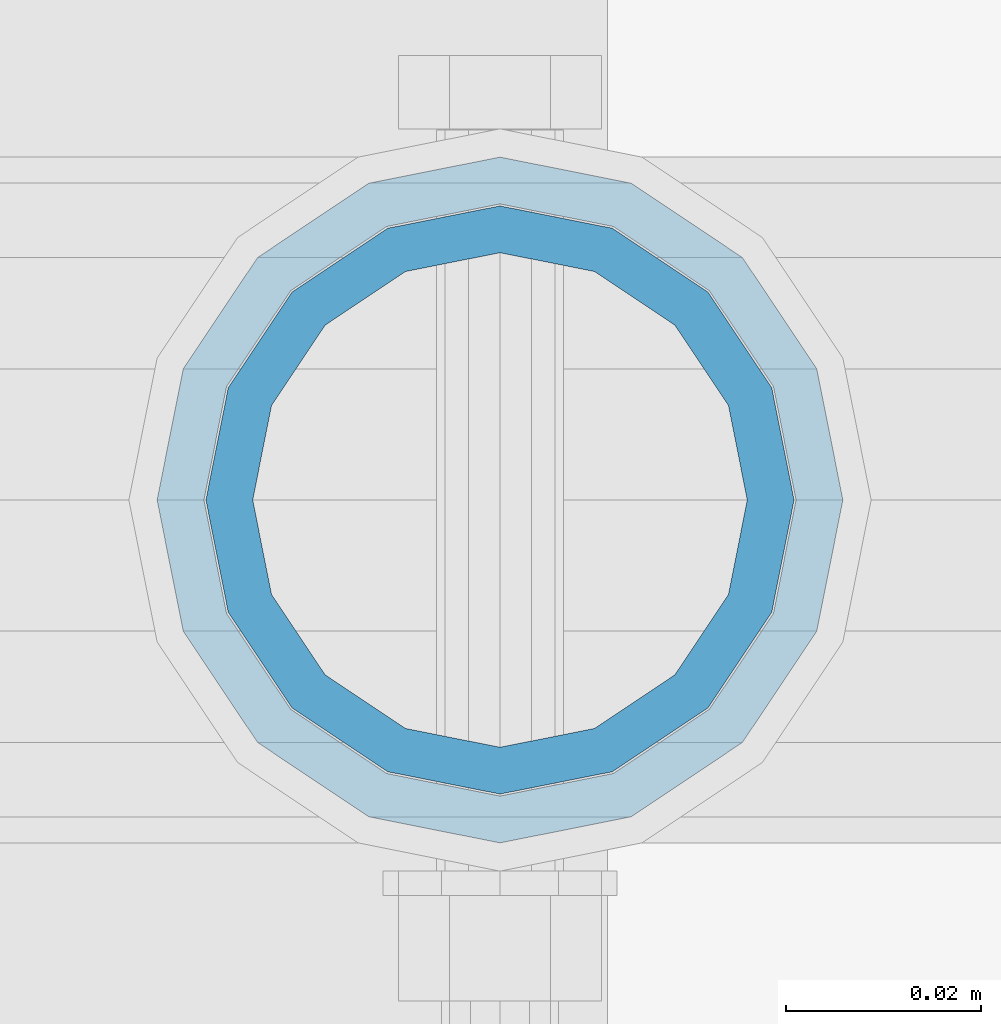
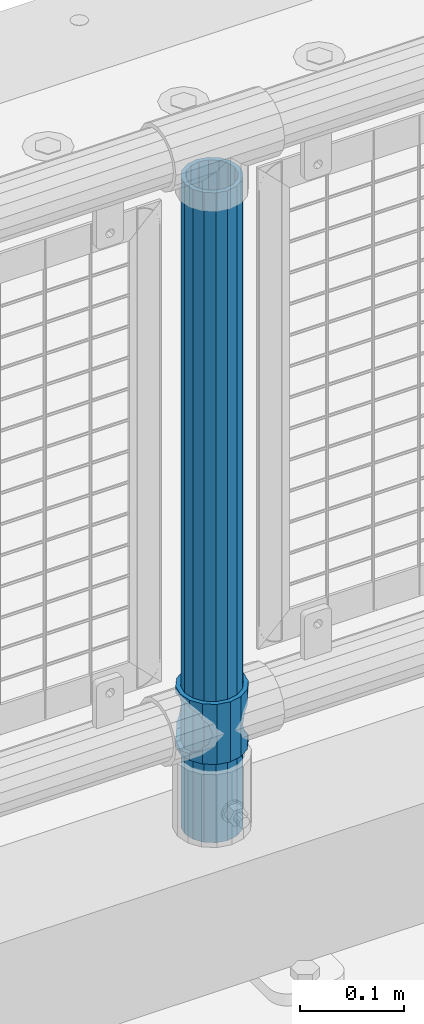
# One storey, part 96 of 242: 2 columns.
"""IFC2X3 building model written with IfcOpenShell, lengths in millimetres."""

import ifcopenshell
import ifcopenshell.guid

model = None  # the IFC model being written
_history = None  # IfcOwnerHistory: only IFC2X3 demands one
_inside = {}  # id of a spatial element -> (the spatial element, [elements in it])
_under = {}  # id of a project, library or spatial element -> (it, [spatial elements below it])
_declared = {}  # id of a project -> (the project, [libraries it declares])
_typed = {}  # id of a type object -> (the type object, [elements of that type])
_made_of = {}  # id of a material, layer set ... -> (it, [elements and type objects made of it])


def new_model(schema):
    """Start an empty IFC model of exactly this schema.

    Asked for "IFC4X3", IfcOpenShell would pick the latest addendum, in which some entities
    have other attributes; the version numbers below select the first issue.
    IFC2X3 requires an IfcOwnerHistory on every rooted entity: one is made here for all.
    """
    global model, _history
    if schema == "IFC4X3":
        model = ifcopenshell.file(schema_version=(4, 3, 0, 0))
    else:
        model = ifcopenshell.file(schema=schema)
    _inside.clear()
    _under.clear()
    _declared.clear()
    _typed.clear()
    _made_of.clear()
    _history = None
    if model.schema == "IFC2X3":
        org = make("IfcOrganization", Name="unknown")
        user = make(
            "IfcPersonAndOrganization",
            ThePerson=make("IfcPerson", FamilyName="unknown"),
            TheOrganization=org,
        )
        app = make(
            "IfcApplication",
            ApplicationDeveloper=org,
            Version="unknown",
            ApplicationFullName="unknown",
            ApplicationIdentifier="unknown",
        )
        _history = make(
            "IfcOwnerHistory",
            OwningUser=user,
            OwningApplication=app,
            ChangeAction="ADDED",
            CreationDate=0,
        )
    return model


def make(cls, **values):
    """One entity of the class cls with the attributes given. An attribute that is None is left unset."""
    return model.create_entity(
        cls, **{name: value for name, value in values.items() if value is not None}
    )


def rooted(cls, **values):
    """An entity with a GlobalId (a new one), such as an element, a storey or a relation."""
    return make(cls, GlobalId=ifcopenshell.guid.new(), OwnerHistory=_history, **values)


def si_unit(unit_type, name, prefix=None):
    """IfcSIUnit, for example si_unit("LENGTHUNIT", "METRE", prefix="MILLI")."""
    return make("IfcSIUnit", UnitType=unit_type, Prefix=prefix, Name=name)


def assignment(units):
    """IfcUnitAssignment: the units of a project."""
    return None if units is None else make("IfcUnitAssignment", Units=units)


def point(xyz):
    """IfcCartesianPoint."""
    return None if xyz is None else make("IfcCartesianPoint", Coordinates=xyz)


def direction(xyz):
    """IfcDirection."""
    return None if xyz is None else make("IfcDirection", DirectionRatios=xyz)


def frame(location, z_axis=None, x_axis=None):
    """IfcAxis2Placement3D, a coordinate frame: its origin and axes. An axis left out is left unset."""
    return make(
        "IfcAxis2Placement3D",
        Location=point(location),
        Axis=direction(z_axis),
        RefDirection=direction(x_axis),
    )


def origin_with_axes():
    """The frame at (0, 0, 0) with the z axis (0, 0, 1) and the x axis (1, 0, 0) written out."""
    return frame((0.0, 0.0, 0.0), z_axis=(0.0, 0.0, 1.0), x_axis=(1.0, 0.0, 0.0))


def place(relative_to, where):
    """IfcLocalPlacement: puts the frame where relative to a parent placement (None: the world)."""
    return make(
        "IfcLocalPlacement", PlacementRelTo=relative_to, RelativePlacement=where
    )


def context(
    kind, dimensions, precision=None, world=None, true_north=None, identifier=None
):
    """IfcGeometricRepresentationContext, for example the 3D "Model" context."""
    return make(
        "IfcGeometricRepresentationContext",
        ContextIdentifier=identifier,
        ContextType=kind,
        CoordinateSpaceDimension=dimensions,
        Precision=precision,
        WorldCoordinateSystem=world,
        TrueNorth=true_north,
    )


def subcontext(parent, identifier, kind, view, scale=None):
    """IfcGeometricRepresentationSubContext, for example "Body" below "Model"."""
    return make(
        "IfcGeometricRepresentationSubContext",
        ContextIdentifier=identifier,
        ContextType=kind,
        ParentContext=parent,
        TargetScale=scale,
        TargetView=view,
    )


def project(units=None, contexts=None):
    """IfcProject with its units and contexts."""
    return rooted(
        "IfcProject",
        Name="project",
        RepresentationContexts=contexts,
        UnitsInContext=assignment(units),
    )


def spatial(cls, under=None, at=None, **own):
    """A site, building, storey or space (cls), placed at a placement, below another one or the project."""
    s = rooted(cls, ObjectPlacement=at, **own)
    if under is not None:
        _under.setdefault(under.id(), (under, []))[1].append(s)
    return s


def faces_of(points, faces, orient=None, outer=None):
    """IfcFace entities. A face is a list of loops; a loop is a list of indices into points, from 0.

    orient and outer hold one flag for each loop. By default every Orientation is true, the
    first loop of a face is its IfcFaceOuterBound and the others are IfcFaceBound.
    """
    made = []
    for i, loops in enumerate(faces):
        bounds = []
        for j, loop in enumerate(loops):
            is_outer = j == 0 if outer is None else outer[i][j]
            bounds.append(
                make(
                    "IfcFaceOuterBound" if is_outer else "IfcFaceBound",
                    Bound=make("IfcPolyLoop", Polygon=[points[k] for k in loop]),
                    Orientation=True if orient is None else orient[i][j],
                )
            )
        made.append(make("IfcFace", Bounds=bounds))
    return made


def faceted_brep(points, faces, orient=None, outer=None, voids=None):
    """IfcFacetedBrep: a solid bounded by flat faces; with voids (closed shells), ...WithVoids."""
    shared = [point(p) for p in points]
    hull = make("IfcClosedShell", CfsFaces=faces_of(shared, faces, orient, outer))
    if voids is None:
        return make("IfcFacetedBrep", Outer=hull)
    return make(
        "IfcFacetedBrepWithVoids",
        Outer=hull,
        Voids=[
            make(cls, CfsFaces=faces_of(shared, fs, o, b)) for cls, fs, o, b in voids
        ],
    )


def shape(context_of_items, identifier, shape_type, items):
    """IfcShapeRepresentation: the items that make up one representation, for example the "Body"."""
    return make(
        "IfcShapeRepresentation",
        ContextOfItems=context_of_items,
        RepresentationIdentifier=identifier,
        RepresentationType=shape_type,
        Items=items,
    )


def material(Name=None, Category=None):
    """IfcMaterial."""
    return make("IfcMaterial", Name=Name, Category=Category)


def made_of(thing, what):
    """Note that an element or type object is made of a material, layer set ...; save() writes the relation."""
    if what is not None:
        _made_of.setdefault(what.id(), (what, []))[1].append(thing)
    return thing


def type_object(cls, material=None, **own):
    """A type object (cls), such as IfcWallType, which elements share."""
    return made_of(rooted(cls, **own), material)


def element(
    cls,
    number,
    at=None,
    inside=None,
    cuts=None,
    type_object=None,
    material=None,
    context=None,
    identifier="Body",
    shape_type=None,
    held_by="IfcProductDefinitionShape",
    body=None,
    shapes=None,
    **own,
):
    """One element of the class cls, such as IfcWall. Its Tag is "e" and its number.

    at: its placement. inside: the storey or other place that contains it. cuts: it is an
    opening in that element (IfcRelVoidsElement). A single representation is given by context,
    identifier, shape_type and body (its items); several are given by shapes. held_by: the class
    of the entity that holds the representations. save() writes the other relations.
    """
    e = rooted(cls, Tag="e%d" % number, ObjectPlacement=at, **own)
    if body is not None:
        shapes = [shape(context, identifier, shape_type, body)]
    if shapes is not None:
        e.Representation = make(held_by, Representations=shapes)
    if inside is not None:
        _inside.setdefault(inside.id(), (inside, []))[1].append(e)
    if cuts is not None:
        rooted(
            "IfcRelVoidsElement", RelatingBuildingElement=cuts, RelatedOpeningElement=e
        )
    if type_object is not None:
        _typed.setdefault(type_object.id(), (type_object, []))[1].append(e)
    return made_of(e, material)


def aggregate(whole, parts):
    """IfcRelAggregates: a whole, such as a stair, and the parts it consists of."""
    return rooted("IfcRelAggregates", RelatingObject=whole, RelatedObjects=parts)


def save(model, path):
    """Write the relations noted so far, then the file.

    IfcRelAggregates (storeys below a building ...), IfcRelContainedInSpatialStructure (elements
    in a storey), IfcRelDefinesByType, IfcRelAssociatesMaterial and IfcRelDeclares: one each for
    every whole, place, type object, material and project.
    """
    for whole, parts in _under.values():
        aggregate(whole, parts)
    for where, things in _inside.values():
        rooted(
            "IfcRelContainedInSpatialStructure",
            RelatedElements=things,
            RelatingStructure=where,
        )
    for kind, things in _typed.values():
        rooted("IfcRelDefinesByType", RelatedObjects=things, RelatingType=kind)
    for what, things in _made_of.values():
        rooted("IfcRelAssociatesMaterial", RelatedObjects=things, RelatingMaterial=what)
    for by, libraries in _declared.values():
        rooted("IfcRelDeclares", RelatingContext=by, RelatedDefinitions=libraries)
    model.write(path)


model = new_model("IFC2X3")

# Units and contexts
model_context = context("Model", 3, precision=1e-05, world=origin_with_axes())
body_context = subcontext(model_context, "Body", "Model", "MODEL_VIEW")
ifc_project = project(units=[si_unit("LENGTHUNIT", "METRE", prefix="MILLI"), si_unit("AREAUNIT", "SQUARE_METRE"), si_unit("VOLUMEUNIT", "CUBIC_METRE"), si_unit("MASSUNIT", "GRAM", prefix="KILO"), si_unit("TIMEUNIT", "SECOND"), si_unit("PLANEANGLEUNIT", "RADIAN"), si_unit("SOLIDANGLEUNIT", "STERADIAN"), si_unit("THERMODYNAMICTEMPERATUREUNIT", "DEGREE_CELSIUS"), si_unit("LUMINOUSINTENSITYUNIT", "LUMEN")], contexts=[model_context])

# Site, building, storey
site_placement = place(None, origin_with_axes())
site = spatial("IfcSite", under=ifc_project, at=site_placement, CompositionType="ELEMENT")
building_placement = place(site_placement, origin_with_axes())
building = spatial("IfcBuilding", under=site, at=building_placement, Name="Standard", CompositionType="ELEMENT")
storey_placement = place(building_placement, origin_with_axes())
storey = spatial("IfcBuildingStorey", under=building, at=storey_placement, Name="Undefined", CompositionType="ELEMENT", Elevation=0.0)

# Columns
ifc_material_1 = material()
column_type_1 = type_object("IfcColumnType", PredefinedType="NOTDEFINED")
column_1_placement = place(storey_placement, frame((-27132.0, -19335.5, 168.02), z_axis=(-1.0, 0.0, 0.0), x_axis=(0.0, 0.0, 1.0)))
element("IfcColumn", 1, at=column_1_placement, inside=storey, type_object=column_type_1, material=ifc_material_1, context=body_context, shape_type="Brep", body=[
    faceted_brep([(0.0, -25.3499999999985, 0.0), (0.0, -23.4203461491597, 9.70102501045403), (760.0, -23.4203461491597, 9.70102501045403), (760.0, -25.3499999999985, 0.0), (0.0, -17.9251569030785, 17.9251569030785), (760.0, -17.9251569030785, 17.9251569030785), (0.0, -9.70102501045403, 23.4203461491597), (760.0, -9.70102501045403, 23.4203461491597), (0.0, 0.0, 25.3499999999985), (760.0, 0.0, 25.3499999999985), (0.0, 9.70102501045403, 23.4203461491597), (760.0, 9.70102501045403, 23.4203461491597), (0.0, 17.9251569030785, 17.9251569030785), (760.0, 17.9251569030785, 17.9251569030785), (0.0, 23.4203461491597, 9.70102501045403), (760.0, 23.4203461491597, 9.70102501045403), (0.0, 25.3499999999985, 0.0), (760.0, 25.3499999999985, 0.0), (0.0, 23.4203461491597, -9.70102501045403), (760.0, 23.4203461491597, -9.70102501045403), (0.0, 17.9251569030785, -17.9251569030785), (760.0, 17.9251569030785, -17.9251569030785), (0.0, 9.70102501045403, -23.4203461491597), (760.0, 9.70102501045403, -23.4203461491597), (0.0, 0.0, -25.3499999999985), (760.0, 0.0, -25.3499999999985), (0.0, -9.70102501045403, -23.4203461491597), (760.0, -9.70102501045403, -23.4203461491597), (0.0, -17.9251569030785, -17.9251569030785), (760.0, -17.9251569030785, -17.9251569030785), (0.0, -23.4203461491597, -9.70102501045403), (760.0, -23.4203461491597, -9.70102501045403), (0.0, -30.1500000000015, 0.0), (0.0, -27.8549679052157, -11.5379054858058), (760.0, -27.8549679052157, -11.5379054858058), (760.0, -30.1500000000015, 0.0), (0.0, -21.3192694527752, -21.3192694527752), (760.0, -21.3192694527752, -21.3192694527752), (0.0, -11.5379054858058, -27.8549679052157), (760.0, -11.5379054858058, -27.8549679052157), (0.0, 0.0, -30.1500000000015), (760.0, 0.0, -30.1500000000015), (0.0, 11.5379054858058, -27.8549679052157), (760.0, 11.5379054858058, -27.8549679052157), (0.0, 21.3192694527752, -21.3192694527752), (760.0, 21.3192694527752, -21.3192694527752), (0.0, 27.8549679052157, -11.5379054858058), (760.0, 27.8549679052157, -11.5379054858058), (0.0, 30.1500000000015, 0.0), (760.0, 30.1500000000015, 0.0), (0.0, 27.8549679052157, 11.5379054858058), (760.0, 27.8549679052157, 11.5379054858058), (0.0, 21.3192694527752, 21.3192694527752), (760.0, 21.3192694527752, 21.3192694527752), (0.0, 11.5379054858058, 27.8549679052157), (760.0, 11.5379054858058, 27.8549679052157), (0.0, 0.0, 30.1500000000015), (760.0, 0.0, 30.1500000000015), (0.0, -11.5379054858058, 27.8549679052157), (760.0, -11.5379054858058, 27.8549679052157), (0.0, -21.3192694527752, 21.3192694527752), (760.0, -21.3192694527752, 21.3192694527752), (0.0, -27.8549679052157, 11.5379054858058), (760.0, -27.8549679052157, 11.5379054858058)], [[[0, 1, 2, 3]], [[1, 4, 5, 2]], [[4, 6, 7, 5]], [[6, 8, 9, 7]], [[8, 10, 11, 9]], [[10, 12, 13, 11]], [[12, 14, 15, 13]], [[14, 16, 17, 15]], [[16, 18, 19, 17]], [[18, 20, 21, 19]], [[20, 22, 23, 21]], [[22, 24, 25, 23]], [[24, 26, 27, 25]], [[26, 28, 29, 27]], [[28, 30, 31, 29]], [[30, 0, 3, 31]], [[32, 33, 34, 35]], [[33, 36, 37, 34]], [[36, 38, 39, 37]], [[38, 40, 41, 39]], [[40, 42, 43, 41]], [[42, 44, 45, 43]], [[44, 46, 47, 45]], [[46, 48, 49, 47]], [[48, 50, 51, 49]], [[50, 52, 53, 51]], [[52, 54, 55, 53]], [[54, 56, 57, 55]], [[56, 58, 59, 57]], [[58, 60, 61, 59]], [[60, 62, 63, 61]], [[62, 32, 35, 63]], [[37, 39, 41, 43, 45, 47, 49, 51, 53, 55, 57, 59, 61, 63, 35, 34], [5, 7, 9, 11, 13, 15, 17, 19, 21, 23, 25, 27, 29, 31, 3, 2]], [[62, 60, 58, 56, 54, 52, 50, 48, 46, 44, 42, 40, 38, 36, 33, 32], [30, 28, 26, 24, 22, 20, 18, 16, 14, 12, 10, 8, 6, 4, 1, 0]]]),
])
ifc_material_2 = material(Name="Misc_Undefined")
column_type_2 = type_object("IfcColumnType", PredefinedType="NOTDEFINED")
column_2_placement = place(storey_placement, frame((-27132.0, -19335.5, 263.02), z_axis=(-1.0, 0.0, 0.0), x_axis=(0.0, 0.0, 1.0)))
element("IfcColumn", 2, at=column_2_placement, inside=storey, type_object=column_type_2, material=ifc_material_2, context=body_context, shape_type="Brep", body=[
    faceted_brep([(63.1897438117172, 11.614442172282, -32.8397438117245), (63.1897438117172, 11.614442172282, -28.0397438117143), (56.6106908090114, 21.46069080901, -21.4606908090136), (56.6106908090114, 21.46069080901, -27.1226768591077), (61.9623795176744, 13.4513226476338, -32.4743655677739), (46.7644421722801, 28.0397438117179, -11.6144421722784), (46.7644421722801, 28.0397438117179, -20.0882031229849), (51.5310424080006, 24.8548033587067, -24.8548033587067), (35.1500000000015, 30.35, 0.0), (35.1499999999996, 30.3499999999985, -16.6306603983685), (23.5355578277192, 28.0397438117179, -11.6144421722784), (23.5355578277192, 28.0397438117179, -20.0882031229849), (18.7689575919987, 24.8548033587067, -24.8548033587067), (13.6893091909879, 21.46069080901, -21.4606908090136), (13.6893091909879, 21.46069080901, -27.1226768591077), (8.33762048232262, 13.4513226476338, -32.4743655677739), (7.11025618828211, 11.614442172282, -28.0397438117143), (7.11025618828211, 11.614442172282, -32.8397438117245), (4.79999999999961, 0.0, -30.3499999999985), (4.79999999999961, 0.0, -35.1500000000015), (7.11025618828211, -11.614442172282, -28.0397438117143), (7.11025618828211, -11.614442172282, -32.8397438117172), (13.6893091909879, -21.46069080901, -21.4606908090136), (13.6893091909879, -21.46069080901, -27.1226768591077), (8.33762048232484, -13.4513226476338, -32.4743655677739), (23.5355578277191, -28.0397438117179, -11.6144421722784), (23.5355578277191, -28.0397438117179, -20.0882031229921), (18.7689575919975, -24.8548033587067, -24.8548033587067), (35.1500000000015, -30.35, 0.0), (35.1499999999996, -30.3499999999985, -16.6306603983758), (46.7644421722801, -28.0397438117179, -11.6144421722784), (46.7644421722801, -28.0397438117179, -20.0882031229921), (51.5310424079973, -24.8548033587067, -24.8548033587067), (56.6106908090114, -21.46069080901, -21.4606908090136), (56.6106908090114, -21.46069080901, -27.1226768591077), (61.9623795176767, -13.4513226476338, -32.4743655677739), (63.1897438117172, -11.614442172282, -28.0397438117143), (63.1897438117172, -11.614442172282, -32.8397438117172), (65.4999999999997, 0.0, -30.3499999999985), (65.4999999999997, 0.0, -35.1500000000015), (0.0, -28.0397438117179, -11.6144421722784), (0.0, -30.3499999999985, 0.0), (0.0, -21.46069080901, -21.4606908090136), (0.0, -11.614442172282, -28.0397438117143), (0.0, 0.0, -30.3499999999985), (0.0, 11.614442172282, -28.0397438117143), (0.0, 21.46069080901, -21.4606908090136), (0.0, 28.0397438117179, -11.6144421722784), (0.0, 30.3499999999985, 0.0), (0.0, 28.0397438117179, 11.6144421722784), (23.5355578277192, 28.0397438117179, 11.614442172282), (0.0, 21.46069080901, 21.4606908090136), (13.6893091909879, 21.46069080901, 21.46069080901), (0.0, 11.614442172282, 28.0397438117143), (7.11025618828211, 11.614442172282, 28.0397438117179), (0.0, 0.0, 30.3499999999985), (4.79999999999961, 0.0, 30.3499999999985), (0.0, -11.614442172282, 28.0397438117143), (7.11025618828205, -11.614442172282, 28.0397438117179), (0.0, -21.46069080901, 21.4606908090136), (13.6893091909879, -21.46069080901, 21.46069080901), (0.0, -28.0397438117179, 11.6144421722784), (23.5355578277191, -28.0397438117179, 11.614442172282), (0.0, -32.4743655677703, 13.4513226476338), (0.0, -35.1500000000015, 0.0), (70.2999999999993, -35.1500000000015, 0.0), (70.2999999999993, -32.4743655677703, 13.4513226476338), (0.0, 13.4513226476338, -32.4743655677739), (0.0, 24.8548033587067, -24.8548033587067), (0.0, 0.0, -35.1500000000015), (0.0, -13.4513226476338, -32.4743655677739), (0.0, -24.8548033587067, -24.8548033587067), (0.0, -24.8548033587067, 24.8548033587067), (0.0, -13.4513226476338, 32.4743655677739), (0.0, 0.0, 35.1500000000015), (0.0, 13.4513226476338, 32.4743655677739), (0.0, 24.8548033587067, 24.8548033587067), (0.0, 32.4743655677703, 13.4513226476338), (0.0, 35.1500000000015, 0.0), (0.0, 32.4743655677703, -13.4513226476338), (0.0, -32.4743655677703, -13.4513226476338), (70.2999999999993, 32.4743655677703, 13.4513226476338), (70.2999999999993, 35.1500000000015, 0.0), (70.2999999999993, 32.4743655677703, -13.4513226476338), (70.2999999999993, 24.8548033587067, -24.8548033587067), (70.2999999999993, 13.4513226476338, -32.4743655677739), (70.2999999999993, 0.0, -35.1500000000015), (70.2999999999993, -13.4513226476338, -32.4743655677739), (70.2999999999993, -24.8548033587067, -24.8548033587067), (70.2999999999993, -32.4743655677703, -13.4513226476338), (70.2999999999993, 28.0397438117179, 11.6144421722784), (70.2999999999993, 21.46069080901, 21.4606908090136), (56.6106908090114, 21.46069080901, 21.46069080901), (46.7644421722801, 28.0397438117179, 11.614442172282), (70.2999999999993, 11.614442172282, 28.0397438117143), (63.1897438117172, 11.614442172282, 28.0397438117179), (70.2999999999993, 0.0, 30.3499999999985), (65.4999999999997, 0.0, 30.3499999999985), (70.2999999999993, -11.614442172282, 28.0397438117143), (63.1897438117172, -11.614442172282, 28.0397438117179), (70.2999999999993, -21.46069080901, 21.4606908090136), (56.6106908090114, -21.46069080901, 21.46069080901), (70.2999999999993, -28.0397438117179, 11.6144421722784), (46.7644421722801, -28.0397438117179, 11.614442172282), (70.2999999999993, -11.614442172282, -28.0397438117143), (70.2999999999993, 0.0, -30.3499999999985), (70.2999999999993, -21.46069080901, -21.4606908090136), (70.2999999999993, -28.0397438117179, -11.6144421722784), (70.2999999999993, -30.3499999999985, 0.0), (70.2999999999993, 24.8548033587067, 24.8548033587067), (70.2999999999993, 13.4513226476338, 32.4743655677739), (70.2999999999993, 0.0, 35.1500000000015), (70.2999999999993, -13.4513226476338, 32.4743655677739), (70.2999999999993, -24.8548033587067, 24.8548033587067), (70.2999999999993, 30.3499999999985, 0.0), (70.2999999999993, 28.0397438117179, -11.6144421722784), (70.2999999999993, 21.46069080901, -21.4606908090136), (70.2999999999993, 11.614442172282, -28.0397438117143), (61.9623795176744, 13.4513226476338, 32.4743655677703), (51.5310424080006, 24.8548033587067, 24.8548033587067), (56.6106908090114, 21.46069080901, 27.1226768591077), (65.4999999999997, 0.0, 35.1500000000015), (63.1897438117172, 11.614442172282, 32.8397438117136), (63.1897438117172, -11.614442172282, 32.8397438117172), (61.9623795176767, -13.4513226476338, 32.4743655677703), (56.6106908090114, -21.46069080901, 27.1226768591077), (51.5310424080038, -24.8548033587067, 24.8548033587067), (18.7689575919954, -24.8548033587067, 24.8548033587067), (46.7644421722801, -28.0397438117179, 20.0882031229885), (35.1499999999996, -30.3499999999985, 16.6306603983685), (23.5355578277191, -28.0397438117179, 20.0882031229885), (8.33762048232484, -13.4513226476338, 32.4743655677703), (13.6893091909879, -21.46069080901, 27.1226768591077), (4.79999999999961, 0.0, 35.1500000000015), (7.11025618828205, -11.614442172282, 32.8397438117172), (7.11025618828211, 11.614442172282, 32.8397438117136), (8.33762048232262, 13.4513226476338, 32.4743655677703), (13.6893091909879, 21.46069080901, 27.1226768591077), (18.768957592002, 24.8548033587067, 24.8548033587067), (23.5355578277192, 28.0397438117179, 20.0882031229812), (35.1499999999996, 30.3499999999985, 16.6306603983721), (46.7644421722801, 28.0397438117179, 20.0882031229812)], [[[0, 1, 2, 3, 4]], [[3, 2, 5, 6, 7]], [[6, 5, 8, 9]], [[9, 8, 10, 11]], [[12, 11, 10, 13, 14]], [[15, 14, 13, 16, 17]], [[17, 16, 18, 19]], [[19, 18, 20, 21]], [[21, 20, 22, 23, 24]], [[23, 22, 25, 26, 27]], [[26, 25, 28, 29]], [[29, 28, 30, 31]], [[32, 31, 30, 33, 34]], [[35, 34, 33, 36, 37]], [[37, 36, 38, 39]], [[39, 38, 1, 0]], [[40, 41, 28, 25]], [[42, 40, 25, 22]], [[43, 42, 22, 20]], [[44, 43, 20, 18]], [[45, 44, 18, 16]], [[46, 45, 16, 13]], [[47, 46, 13, 10]], [[48, 47, 10, 8]], [[49, 48, 8, 50]], [[51, 49, 50, 52]], [[53, 51, 52, 54]], [[55, 53, 54, 56]], [[57, 55, 56, 58]], [[59, 57, 58, 60]], [[61, 59, 60, 62]], [[41, 61, 62, 28]], [[63, 64, 65, 66]], [[67, 68, 12, 14, 15]], [[69, 67, 15, 17, 19]], [[24, 70, 69, 19, 21]], [[27, 71, 70, 24, 23]], [[63, 72, 73, 74, 75, 76, 77, 78, 79, 68, 67, 69, 70, 71, 80, 64], [40, 42, 43, 44, 45, 46, 47, 48, 49, 51, 53, 55, 57, 59, 61, 41]], [[78, 77, 81, 82]], [[79, 78, 82, 83]], [[68, 79, 83, 84, 7, 6, 9, 11, 12]], [[7, 84, 85, 4, 3]], [[4, 85, 86, 39, 0]], [[87, 88, 32, 34, 35]], [[86, 87, 35, 37, 39]], [[29, 31, 32, 88, 89, 80, 71, 27, 26]], [[64, 80, 89, 65]], [[90, 91, 92, 93]], [[91, 94, 95, 92]], [[94, 96, 97, 95]], [[96, 98, 99, 97]], [[98, 100, 101, 99]], [[100, 102, 103, 101]], [[104, 105, 38, 36]], [[106, 104, 36, 33]], [[107, 106, 33, 30]], [[108, 107, 30, 28]], [[102, 108, 28, 103]], [[88, 87, 86, 85, 84, 83, 82, 81, 109, 110, 111, 112, 113, 66, 65, 89], [100, 98, 96, 94, 91, 90, 114, 115, 116, 117, 105, 104, 106, 107, 108, 102]], [[118, 110, 109, 119, 120]], [[121, 111, 110, 118, 122]], [[112, 111, 121, 123, 124]], [[113, 112, 124, 125, 126]], [[127, 72, 63, 66, 113, 126, 128, 129, 130]], [[131, 73, 72, 127, 132]], [[133, 74, 73, 131, 134]], [[75, 74, 133, 135, 136]], [[76, 75, 136, 137, 138]], [[119, 109, 81, 77, 76, 138, 139, 140, 141]], [[92, 120, 119, 141, 93]], [[95, 122, 118, 120, 92]], [[97, 121, 122, 95]], [[99, 123, 121, 97]], [[101, 125, 124, 123, 99]], [[103, 128, 126, 125, 101]], [[28, 129, 128, 103]], [[62, 130, 129, 28]], [[60, 132, 127, 130, 62]], [[58, 134, 131, 132, 60]], [[56, 133, 134, 58]], [[54, 135, 133, 56]], [[52, 137, 136, 135, 54]], [[50, 139, 138, 137, 52]], [[8, 140, 139, 50]], [[93, 141, 140, 8]], [[114, 90, 93, 8]], [[115, 114, 8, 5]], [[116, 115, 5, 2]], [[117, 116, 2, 1]], [[105, 117, 1, 38]]]),
])

save(model, "model.ifc")
